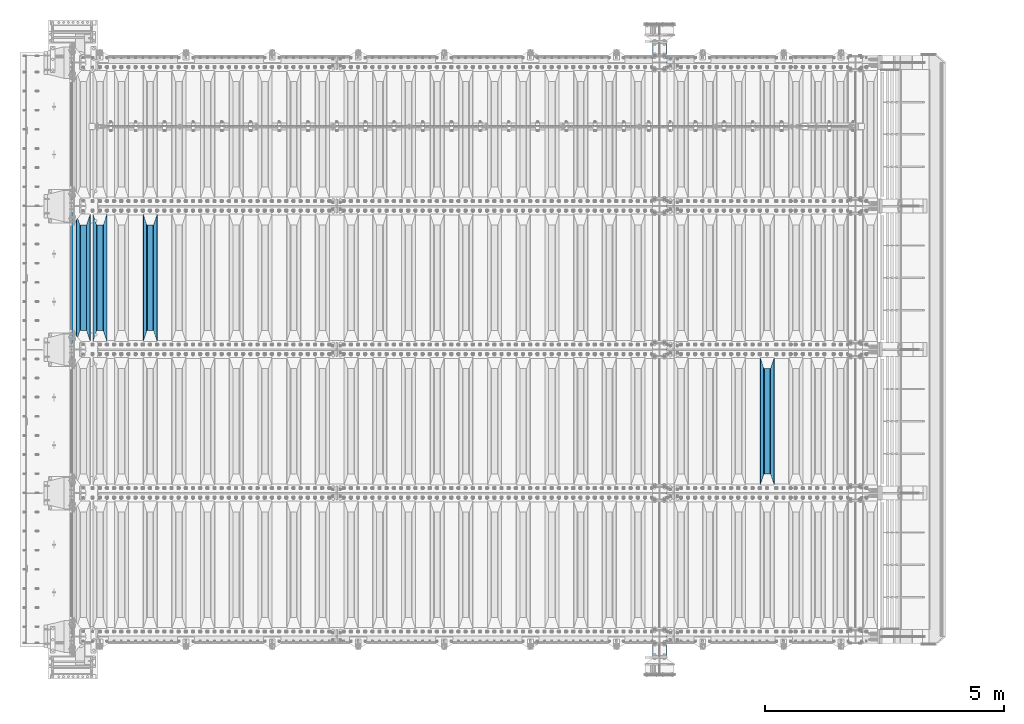
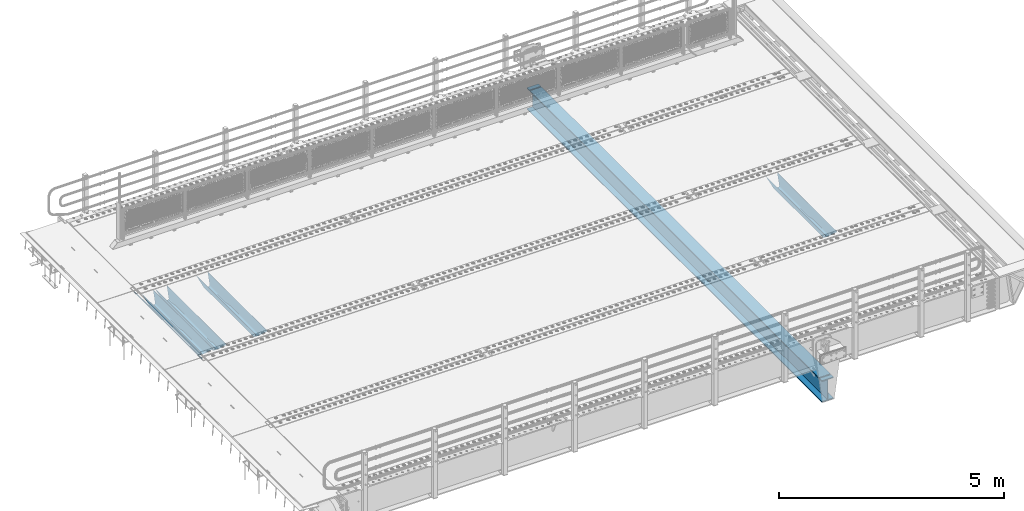
# One storey, part 113 of 257: 6 beams.
"""IFC2X3 building model written with IfcOpenShell, lengths in millimetres."""

from ifc_helpers import new_model, si_unit, frame, origin_with_axes, place, context, subcontext, project, spatial, faceted_brep, material, type_object, element, save


model = new_model("IFC2X3")

# Units and contexts
model_context = context("Model", 3, precision=1e-05, world=origin_with_axes())
body_context = subcontext(model_context, "Body", "Model", "MODEL_VIEW")
ifc_project = project(units=[si_unit("LENGTHUNIT", "METRE", prefix="MILLI"), si_unit("AREAUNIT", "SQUARE_METRE"), si_unit("VOLUMEUNIT", "CUBIC_METRE"), si_unit("MASSUNIT", "GRAM", prefix="KILO"), si_unit("TIMEUNIT", "SECOND"), si_unit("PLANEANGLEUNIT", "RADIAN"), si_unit("SOLIDANGLEUNIT", "STERADIAN"), si_unit("THERMODYNAMICTEMPERATUREUNIT", "DEGREE_CELSIUS"), si_unit("LUMINOUSINTENSITYUNIT", "LUMEN")], contexts=[model_context])

# Site, building, storey
site_placement = place(None, origin_with_axes())
site = spatial("IfcSite", under=ifc_project, at=site_placement, CompositionType="ELEMENT")
building_placement = place(site_placement, origin_with_axes())
building = spatial("IfcBuilding", under=site, at=building_placement, Name="Standard", CompositionType="ELEMENT")
storey_placement = place(building_placement, origin_with_axes())
storey = spatial("IfcBuildingStorey", under=building, at=storey_placement, Name="Undefined", CompositionType="ELEMENT", Elevation=0.0)

# Beams
ifc_material = material(Name="STEEL/S355N")
beam_type_1 = type_object("IfcBeamType", Name="D20", PredefinedType="NOTDEFINED")
beam_1_placement = place(storey_placement, frame((42415.0, 6004.99999999998, -25.999999994595), z_axis=(0.0, 0.0, 1.0), x_axis=(0.0, 1.0, 0.0)))
element("IfcBeam", 1, at=beam_1_placement, inside=storey, type_object=beam_type_1, material=ifc_material, ObjectType="D20", context=body_context, shape_type="Brep", body=[
    faceted_brep([(0.0, -10.0, 0.0), (0.0, -7.07106781186303, -7.07106781186548), (2990.0, -7.07106781186303, -7.07106781186548), (2990.0, -10.0, 0.0), (0.0, 0.0, -10.0), (2990.0, 0.0, -10.0), (0.0, 7.07106781186303, -7.07106781186547), (2990.0, 7.07106781186303, -7.07106781186547), (0.0, 10.0, 0.0), (2990.0, 10.0, 0.0), (0.0, 7.07106781186303, 7.07106781186548), (2990.0, 7.07106781186303, 7.07106781186548), (0.0, 0.0, 10.0), (2990.0, 0.0, 10.0), (0.0, -7.07106781186303, 7.07106781186548), (2990.0, -7.07106781186303, 7.07106781186548)], [[[0, 1, 2, 3]], [[1, 4, 5, 2]], [[4, 6, 7, 5]], [[6, 8, 9, 7]], [[8, 10, 11, 9]], [[10, 12, 13, 11]], [[12, 14, 15, 13]], [[14, 0, 3, 15]], [[5, 7, 9, 11, 13, 15, 3, 2]], [[14, 12, 10, 8, 6, 4, 1, 0]]]),
])
beam_type_2 = type_object("IfcBeamType", PredefinedType="NOTDEFINED")
beam_2_placement = place(storey_placement, frame((56950.0, 3175.0, -115.0), z_axis=(0.0, 0.0, 1.0), x_axis=(0.0, 1.0, 0.0)))
element("IfcBeam", 2, at=beam_2_placement, inside=storey, type_object=beam_type_2, material=ifc_material, context=body_context, shape_type="Brep", body=[
    faceted_brep([(0.0, 150.0, 115.0), (0.0, 143.690000000002, 115.0), (2650.00000000297, 143.690000000002, 115.0), (2650.00000000297, 150.0, 115.0), (2650.00000000297, 142.059565218406, 110.0000000031), (2650.00000000297, 148.369565218403, 110.0000000031), (2441.90079219208, -80.1103600731149, -98.0992078077845), (2437.7588105432, -77.5672621345584, -102.241189456673), (2434.06523489746, -74.4080125315522, -105.934765102404), (2430.91086095089, -70.7102721255724, -109.089139048974), (2428.37322971128, -66.5649389910031, -111.626770288588), (2426.51472138055, -62.0739139532889, -113.485278619323), (2425.38102192091, -57.3475956567636, -114.618978078955), (2424.99999999987, -52.5021667386536, -115.0), (2424.99999999987, 52.5021667386536, -115.0), (2425.38102192091, 57.3475956567636, -114.618978078955), (2426.51472138055, 62.0739139532889, -113.485278619323), (2428.37322971128, 66.5649389910031, -111.626770288588), (2430.91086095089, 70.7102721255724, -109.089139048974), (2434.06523489746, 74.4080125315522, -105.934765102404), (2437.7588105432, 77.5672621345584, -102.241189456673), (2441.90079219208, 80.1103600731149, -98.0992078077846), (2446.38936140511, 81.9747917625791, -93.6106385947584), (2448.24948500409, 76.2713538057287, -91.7505149957729), (2444.62967112262, 74.76777986261, -95.3703288772456), (2441.28936334126, 72.7168944282894, -98.710636658607), (2438.31067330438, 70.1691124903809, -101.689326695487), (2435.76682334747, 67.1870637758839, -104.233176652398), (2433.72034654133, 63.8440531834931, -106.279653458539), (2432.22154950041, 60.2222587982324, -107.778450499454), (2431.30727574265, 56.4107117849126, -108.692724257221), (2430.99999999987, 52.5031078186876, -109.0), (2430.99999999987, -52.5031078186876, -109.0), (2431.30727574265, -56.4107117849126, -108.692724257221), (2432.22154950041, -60.2222587982324, -107.778450499454), (2433.72034654133, -63.8440531834931, -106.279653458539), (2435.76682334747, -67.1870637758839, -104.233176652398), (2438.31067330438, -70.1691124903809, -101.689326695487), (2441.28936334126, -72.7168944282894, -98.7106366586071), (2444.62967112262, -74.76777986261, -95.3703288772457), (2448.24948500409, -76.2713538057287, -91.7505149957729), (2650.00000000297, -142.059565218406, 110.0000000031), (2650.00000000297, -148.369565218403, 110.0000000031), (2446.38936140511, -81.9747917625791, -93.6106385947584), (2650.00000000297, -143.690000000002, 115.0), (2650.00000000297, -150.0, 115.0), (0.0, -143.690000000002, 115.0), (0.0, -150.0, 115.0), (0.0, -148.369565218258, 110.000000002662), (203.61063859742, -81.9747917625791, -93.6106385947584), (208.099207810447, -80.1103600731149, -98.0992078077845), (212.241189459335, -77.5672621345584, -102.241189456673), (215.934765105066, -74.4080125315522, -105.934765102404), (219.089139051636, -70.7102721255724, -109.089139048974), (221.626770291251, -66.5649389910031, -111.626770288588), (223.485278621985, -62.0739139532889, -113.485278619323), (224.618978081617, -57.3475956567636, -114.618978078955), (225.000000002662, -52.5021667386536, -115.0), (225.000000002662, 52.5021667386536, -115.0), (224.618978081617, 57.3475956567636, -114.618978078955), (223.485278621985, 62.0739139532889, -113.485278619323), (221.626770291251, 66.5649389910031, -111.626770288588), (219.089139051636, 70.7102721255724, -109.089139048974), (215.934765105066, 74.4080125315522, -105.934765102404), (212.241189459335, 77.5672621345584, -102.241189456673), (208.099207810447, 80.1103600731149, -98.0992078077846), (203.61063859742, 81.9747917625791, -93.6106385947584), (0.0, 148.369565218258, 110.000000002662), (0.0, 142.05956521826, 110.000000002662), (201.750514998435, 76.2713538057287, -91.7505149957729), (205.370328879908, 74.76777986261, -95.3703288772456), (208.710636661269, 72.7168944282894, -98.710636658607), (211.689326698149, 70.1691124903809, -101.689326695487), (214.233176655061, 67.1870637758839, -104.233176652398), (216.279653461201, 63.8440531834931, -106.279653458539), (217.778450502116, 60.2222587982324, -107.778450499454), (218.692724259884, 56.4107117849126, -108.692724257221), (219.000000002662, 52.5031078186876, -109.0), (219.000000002662, -52.5031078186876, -109.0), (218.692724259884, -56.4107117849126, -108.692724257221), (217.778450502116, -60.2222587982324, -107.778450499454), (216.279653461201, -63.8440531834931, -106.279653458539), (214.233176655061, -67.1870637758839, -104.233176652398), (211.689326698149, -70.1691124903809, -101.689326695487), (208.710636661269, -72.7168944282894, -98.7106366586071), (205.370328879908, -74.76777986261, -95.3703288772457), (201.750514998435, -76.2713538057287, -91.7505149957729), (0.0, -142.05956521826, 110.000000002662)], [[[0, 1, 2, 3]], [[3, 2, 4, 5]], [[6, 7, 8, 9, 10, 11, 12, 13, 14, 15, 16, 17, 18, 19, 20, 21, 22, 5, 4, 23, 24, 25, 26, 27, 28, 29, 30, 31, 32, 33, 34, 35, 36, 37, 38, 39, 40, 41, 42, 43]], [[44, 45, 42, 41]], [[46, 47, 45, 44]], [[43, 42, 45, 47, 48, 49]], [[6, 43, 49, 50]], [[7, 6, 50, 51]], [[8, 7, 51, 52]], [[9, 8, 52, 53]], [[10, 9, 53, 54]], [[11, 10, 54, 55]], [[12, 11, 55, 56]], [[13, 12, 56, 57]], [[14, 13, 57, 58]], [[15, 14, 58, 59]], [[16, 15, 59, 60]], [[17, 16, 60, 61]], [[18, 17, 61, 62]], [[19, 18, 62, 63]], [[20, 19, 63, 64]], [[21, 20, 64, 65]], [[22, 21, 65, 66]], [[0, 3, 5, 22, 66, 67]], [[1, 0, 67, 68]], [[23, 4, 2, 1, 68, 69]], [[24, 23, 69, 70]], [[25, 24, 70, 71]], [[26, 25, 71, 72]], [[27, 26, 72, 73]], [[28, 27, 73, 74]], [[29, 28, 74, 75]], [[30, 29, 75, 76]], [[31, 30, 76, 77]], [[32, 31, 77, 78]], [[33, 32, 78, 79]], [[34, 33, 79, 80]], [[35, 34, 80, 81]], [[36, 35, 81, 82]], [[37, 36, 82, 83]], [[38, 37, 83, 84]], [[39, 38, 84, 85]], [[40, 39, 85, 86]], [[46, 44, 41, 40, 86, 87]], [[47, 46, 87, 48]], [[86, 85, 84, 83, 82, 81, 80, 79, 78, 77, 76, 75, 74, 73, 72, 71, 70, 69, 68, 67, 66, 65, 64, 63, 62, 61, 60, 59, 58, 57, 56, 55, 54, 53, 52, 51, 50, 49, 48, 87]]]),
])
beam_3_placement = place(storey_placement, frame((44050.0, 6175.0, -115.0), z_axis=(0.0, 0.0, 1.0), x_axis=(0.0, 1.0, 0.0)))
element("IfcBeam", 3, at=beam_3_placement, inside=storey, type_object=beam_type_2, material=ifc_material, context=body_context, shape_type="Brep", body=[
    faceted_brep([(0.0, 150.0, 115.0), (0.0, 143.690000000002, 115.0), (2650.00000000297, 143.690000000002, 115.0), (2650.00000000297, 150.0, 115.0), (2650.00000000297, 142.059565218406, 110.0000000031), (2650.00000000297, 148.369565218403, 110.0000000031), (2441.90079219208, -80.1103600731149, -98.0992078077845), (2437.7588105432, -77.5672621345584, -102.241189456673), (2434.06523489746, -74.4080125315522, -105.934765102404), (2430.91086095089, -70.7102721255724, -109.089139048974), (2428.37322971128, -66.5649389910031, -111.626770288588), (2426.51472138055, -62.0739139532889, -113.485278619323), (2425.38102192091, -57.3475956567636, -114.618978078955), (2424.99999999987, -52.5021667386536, -115.0), (2424.99999999987, 52.5021667386536, -115.0), (2425.38102192091, 57.3475956567636, -114.618978078955), (2426.51472138055, 62.0739139532889, -113.485278619323), (2428.37322971128, 66.5649389910031, -111.626770288588), (2430.91086095089, 70.7102721255724, -109.089139048974), (2434.06523489746, 74.4080125315522, -105.934765102404), (2437.7588105432, 77.5672621345584, -102.241189456673), (2441.90079219208, 80.1103600731149, -98.0992078077846), (2446.38936140511, 81.9747917625791, -93.6106385947584), (2448.24948500409, 76.2713538057287, -91.7505149957729), (2444.62967112262, 74.76777986261, -95.3703288772456), (2441.28936334126, 72.7168944282894, -98.710636658607), (2438.31067330438, 70.1691124903809, -101.689326695487), (2435.76682334747, 67.1870637758839, -104.233176652398), (2433.72034654133, 63.8440531834931, -106.279653458539), (2432.22154950041, 60.2222587982324, -107.778450499454), (2431.30727574265, 56.4107117849126, -108.692724257221), (2430.99999999987, 52.5031078186876, -109.0), (2430.99999999987, -52.5031078186876, -109.0), (2431.30727574265, -56.4107117849126, -108.692724257221), (2432.22154950041, -60.2222587982324, -107.778450499454), (2433.72034654133, -63.8440531834931, -106.279653458539), (2435.76682334747, -67.1870637758839, -104.233176652398), (2438.31067330438, -70.1691124903809, -101.689326695487), (2441.28936334126, -72.7168944282894, -98.7106366586071), (2444.62967112262, -74.76777986261, -95.3703288772457), (2448.24948500409, -76.2713538057287, -91.7505149957729), (2650.00000000297, -142.059565218406, 110.0000000031), (2650.00000000297, -148.369565218403, 110.0000000031), (2446.38936140511, -81.9747917625791, -93.6106385947584), (2650.00000000297, -143.690000000002, 115.0), (2650.00000000297, -150.0, 115.0), (0.0, -143.690000000002, 115.0), (0.0, -150.0, 115.0), (0.0, -148.369565218258, 110.000000002662), (203.61063859742, -81.9747917625791, -93.6106385947584), (208.099207810447, -80.1103600731149, -98.0992078077845), (212.241189459335, -77.5672621345584, -102.241189456673), (215.934765105066, -74.4080125315522, -105.934765102404), (219.089139051636, -70.7102721255724, -109.089139048974), (221.626770291251, -66.5649389910031, -111.626770288588), (223.485278621985, -62.0739139532889, -113.485278619323), (224.618978081617, -57.3475956567636, -114.618978078955), (225.000000002662, -52.5021667386536, -115.0), (225.000000002662, 52.5021667386536, -115.0), (224.618978081617, 57.3475956567636, -114.618978078955), (223.485278621985, 62.0739139532889, -113.485278619323), (221.626770291251, 66.5649389910031, -111.626770288588), (219.089139051636, 70.7102721255724, -109.089139048974), (215.934765105066, 74.4080125315522, -105.934765102404), (212.241189459335, 77.5672621345584, -102.241189456673), (208.099207810447, 80.1103600731149, -98.0992078077846), (203.61063859742, 81.9747917625791, -93.6106385947584), (0.0, 148.369565218258, 110.000000002662), (0.0, 142.05956521826, 110.000000002662), (201.750514998435, 76.2713538057287, -91.7505149957729), (205.370328879908, 74.76777986261, -95.3703288772456), (208.710636661269, 72.7168944282894, -98.710636658607), (211.689326698149, 70.1691124903809, -101.689326695487), (214.233176655061, 67.1870637758839, -104.233176652398), (216.279653461201, 63.8440531834931, -106.279653458539), (217.778450502116, 60.2222587982324, -107.778450499454), (218.692724259884, 56.4107117849126, -108.692724257221), (219.000000002662, 52.5031078186876, -109.0), (219.000000002662, -52.5031078186876, -109.0), (218.692724259884, -56.4107117849126, -108.692724257221), (217.778450502116, -60.2222587982324, -107.778450499454), (216.279653461201, -63.8440531834931, -106.279653458539), (214.233176655061, -67.1870637758839, -104.233176652398), (211.689326698149, -70.1691124903809, -101.689326695487), (208.710636661269, -72.7168944282894, -98.7106366586071), (205.370328879908, -74.76777986261, -95.3703288772457), (201.750514998435, -76.2713538057287, -91.7505149957729), (0.0, -142.05956521826, 110.000000002662)], [[[0, 1, 2, 3]], [[3, 2, 4, 5]], [[6, 7, 8, 9, 10, 11, 12, 13, 14, 15, 16, 17, 18, 19, 20, 21, 22, 5, 4, 23, 24, 25, 26, 27, 28, 29, 30, 31, 32, 33, 34, 35, 36, 37, 38, 39, 40, 41, 42, 43]], [[44, 45, 42, 41]], [[46, 47, 45, 44]], [[43, 42, 45, 47, 48, 49]], [[6, 43, 49, 50]], [[7, 6, 50, 51]], [[8, 7, 51, 52]], [[9, 8, 52, 53]], [[10, 9, 53, 54]], [[11, 10, 54, 55]], [[12, 11, 55, 56]], [[13, 12, 56, 57]], [[14, 13, 57, 58]], [[15, 14, 58, 59]], [[16, 15, 59, 60]], [[17, 16, 60, 61]], [[18, 17, 61, 62]], [[19, 18, 62, 63]], [[20, 19, 63, 64]], [[21, 20, 64, 65]], [[22, 21, 65, 66]], [[0, 3, 5, 22, 66, 67]], [[1, 0, 67, 68]], [[23, 4, 2, 1, 68, 69]], [[24, 23, 69, 70]], [[25, 24, 70, 71]], [[26, 25, 71, 72]], [[27, 26, 72, 73]], [[28, 27, 73, 74]], [[29, 28, 74, 75]], [[30, 29, 75, 76]], [[31, 30, 76, 77]], [[32, 31, 77, 78]], [[33, 32, 78, 79]], [[34, 33, 79, 80]], [[35, 34, 80, 81]], [[36, 35, 81, 82]], [[37, 36, 82, 83]], [[38, 37, 83, 84]], [[39, 38, 84, 85]], [[40, 39, 85, 86]], [[46, 44, 41, 40, 86, 87]], [[47, 46, 87, 48]], [[86, 85, 84, 83, 82, 81, 80, 79, 78, 77, 76, 75, 74, 73, 72, 71, 70, 69, 68, 67, 66, 65, 64, 63, 62, 61, 60, 59, 58, 57, 56, 55, 54, 53, 52, 51, 50, 49, 48, 87]]]),
])
beam_4_placement = place(storey_placement, frame((43000.0, 6175.0, -115.0), z_axis=(0.0, 0.0, 1.0), x_axis=(0.0, 1.0, 0.0)))
element("IfcBeam", 4, at=beam_4_placement, inside=storey, type_object=beam_type_2, material=ifc_material, context=body_context, shape_type="Brep", body=[
    faceted_brep([(0.0, 150.0, 115.0), (0.0, 143.690000000002, 115.0), (2650.00000000297, 143.690000000002, 115.0), (2650.00000000297, 150.0, 115.0), (2650.00000000297, 142.059565218406, 110.0000000031), (2650.00000000297, 148.369565218403, 110.0000000031), (2441.90079219208, -80.1103600731149, -98.0992078077845), (2437.7588105432, -77.5672621345584, -102.241189456673), (2434.06523489746, -74.4080125315522, -105.934765102404), (2430.91086095089, -70.7102721255724, -109.089139048974), (2428.37322971128, -66.5649389910031, -111.626770288588), (2426.51472138055, -62.0739139532889, -113.485278619323), (2425.38102192091, -57.3475956567636, -114.618978078955), (2424.99999999987, -52.5021667386536, -115.0), (2424.99999999987, 52.5021667386536, -115.0), (2425.38102192091, 57.3475956567636, -114.618978078955), (2426.51472138055, 62.0739139532889, -113.485278619323), (2428.37322971128, 66.5649389910031, -111.626770288588), (2430.91086095089, 70.7102721255724, -109.089139048974), (2434.06523489746, 74.4080125315522, -105.934765102404), (2437.7588105432, 77.5672621345584, -102.241189456673), (2441.90079219208, 80.1103600731149, -98.0992078077846), (2446.38936140511, 81.9747917625791, -93.6106385947584), (2448.24948500409, 76.2713538057287, -91.7505149957729), (2444.62967112262, 74.76777986261, -95.3703288772456), (2441.28936334126, 72.7168944282894, -98.710636658607), (2438.31067330438, 70.1691124903809, -101.689326695487), (2435.76682334747, 67.1870637758839, -104.233176652398), (2433.72034654133, 63.8440531834931, -106.279653458539), (2432.22154950041, 60.2222587982324, -107.778450499454), (2431.30727574265, 56.4107117849126, -108.692724257221), (2430.99999999987, 52.5031078186876, -109.0), (2430.99999999987, -52.5031078186876, -109.0), (2431.30727574265, -56.4107117849126, -108.692724257221), (2432.22154950041, -60.2222587982324, -107.778450499454), (2433.72034654133, -63.8440531834931, -106.279653458539), (2435.76682334747, -67.1870637758839, -104.233176652398), (2438.31067330438, -70.1691124903809, -101.689326695487), (2441.28936334126, -72.7168944282894, -98.7106366586071), (2444.62967112262, -74.76777986261, -95.3703288772457), (2448.24948500409, -76.2713538057287, -91.7505149957729), (2650.00000000297, -142.059565218406, 110.0000000031), (2650.00000000297, -148.369565218403, 110.0000000031), (2446.38936140511, -81.9747917625791, -93.6106385947584), (2650.00000000297, -143.690000000002, 115.0), (2650.00000000297, -150.0, 115.0), (0.0, -143.690000000002, 115.0), (0.0, -150.0, 115.0), (0.0, -148.369565218258, 110.000000002662), (203.61063859742, -81.9747917625791, -93.6106385947584), (208.099207810447, -80.1103600731149, -98.0992078077845), (212.241189459335, -77.5672621345584, -102.241189456673), (215.934765105066, -74.4080125315522, -105.934765102404), (219.089139051636, -70.7102721255724, -109.089139048974), (221.626770291251, -66.5649389910031, -111.626770288588), (223.485278621985, -62.0739139532889, -113.485278619323), (224.618978081617, -57.3475956567636, -114.618978078955), (225.000000002662, -52.5021667386536, -115.0), (225.000000002662, 52.5021667386536, -115.0), (224.618978081617, 57.3475956567636, -114.618978078955), (223.485278621985, 62.0739139532889, -113.485278619323), (221.626770291251, 66.5649389910031, -111.626770288588), (219.089139051636, 70.7102721255724, -109.089139048974), (215.934765105066, 74.4080125315522, -105.934765102404), (212.241189459335, 77.5672621345584, -102.241189456673), (208.099207810447, 80.1103600731149, -98.0992078077846), (203.61063859742, 81.9747917625791, -93.6106385947584), (0.0, 148.369565218258, 110.000000002662), (0.0, 142.05956521826, 110.000000002662), (201.750514998435, 76.2713538057287, -91.7505149957729), (205.370328879908, 74.76777986261, -95.3703288772456), (208.710636661269, 72.7168944282894, -98.710636658607), (211.689326698149, 70.1691124903809, -101.689326695487), (214.233176655061, 67.1870637758839, -104.233176652398), (216.279653461201, 63.8440531834931, -106.279653458539), (217.778450502116, 60.2222587982324, -107.778450499454), (218.692724259884, 56.4107117849126, -108.692724257221), (219.000000002662, 52.5031078186876, -109.0), (219.000000002662, -52.5031078186876, -109.0), (218.692724259884, -56.4107117849126, -108.692724257221), (217.778450502116, -60.2222587982324, -107.778450499454), (216.279653461201, -63.8440531834931, -106.279653458539), (214.233176655061, -67.1870637758839, -104.233176652398), (211.689326698149, -70.1691124903809, -101.689326695487), (208.710636661269, -72.7168944282894, -98.7106366586071), (205.370328879908, -74.76777986261, -95.3703288772457), (201.750514998435, -76.2713538057287, -91.7505149957729), (0.0, -142.05956521826, 110.000000002662)], [[[0, 1, 2, 3]], [[3, 2, 4, 5]], [[6, 7, 8, 9, 10, 11, 12, 13, 14, 15, 16, 17, 18, 19, 20, 21, 22, 5, 4, 23, 24, 25, 26, 27, 28, 29, 30, 31, 32, 33, 34, 35, 36, 37, 38, 39, 40, 41, 42, 43]], [[44, 45, 42, 41]], [[46, 47, 45, 44]], [[43, 42, 45, 47, 48, 49]], [[6, 43, 49, 50]], [[7, 6, 50, 51]], [[8, 7, 51, 52]], [[9, 8, 52, 53]], [[10, 9, 53, 54]], [[11, 10, 54, 55]], [[12, 11, 55, 56]], [[13, 12, 56, 57]], [[14, 13, 57, 58]], [[15, 14, 58, 59]], [[16, 15, 59, 60]], [[17, 16, 60, 61]], [[18, 17, 61, 62]], [[19, 18, 62, 63]], [[20, 19, 63, 64]], [[21, 20, 64, 65]], [[22, 21, 65, 66]], [[0, 3, 5, 22, 66, 67]], [[1, 0, 67, 68]], [[23, 4, 2, 1, 68, 69]], [[24, 23, 69, 70]], [[25, 24, 70, 71]], [[26, 25, 71, 72]], [[27, 26, 72, 73]], [[28, 27, 73, 74]], [[29, 28, 74, 75]], [[30, 29, 75, 76]], [[31, 30, 76, 77]], [[32, 31, 77, 78]], [[33, 32, 78, 79]], [[34, 33, 79, 80]], [[35, 34, 80, 81]], [[36, 35, 81, 82]], [[37, 36, 82, 83]], [[38, 37, 83, 84]], [[39, 38, 84, 85]], [[40, 39, 85, 86]], [[46, 44, 41, 40, 86, 87]], [[47, 46, 87, 48]], [[86, 85, 84, 83, 82, 81, 80, 79, 78, 77, 76, 75, 74, 73, 72, 71, 70, 69, 68, 67, 66, 65, 64, 63, 62, 61, 60, 59, 58, 57, 56, 55, 54, 53, 52, 51, 50, 49, 48, 87]]]),
])
beam_5_placement = place(storey_placement, frame((42650.0, 6175.0, -115.0), z_axis=(0.0, 0.0, 1.0), x_axis=(0.0, 1.0, 0.0)))
element("IfcBeam", 5, at=beam_5_placement, inside=storey, type_object=beam_type_2, material=ifc_material, context=body_context, shape_type="Brep", body=[
    faceted_brep([(0.0, 150.0, 115.0), (0.0, 143.690000000002, 115.0), (2650.00000000297, 143.690000000002, 115.0), (2650.00000000297, 150.0, 115.0), (2650.00000000297, 142.059565218406, 110.0000000031), (2650.00000000297, 148.369565218403, 110.0000000031), (2441.90079219208, -80.1103600731149, -98.0992078077845), (2437.7588105432, -77.5672621345584, -102.241189456673), (2434.06523489746, -74.4080125315522, -105.934765102404), (2430.91086095089, -70.7102721255724, -109.089139048974), (2428.37322971128, -66.5649389910031, -111.626770288588), (2426.51472138055, -62.0739139532889, -113.485278619323), (2425.38102192091, -57.3475956567636, -114.618978078955), (2424.99999999987, -52.5021667386536, -115.0), (2424.99999999987, 52.5021667386536, -115.0), (2425.38102192091, 57.3475956567636, -114.618978078955), (2426.51472138055, 62.0739139532889, -113.485278619323), (2428.37322971128, 66.5649389910031, -111.626770288588), (2430.91086095089, 70.7102721255724, -109.089139048974), (2434.06523489746, 74.4080125315522, -105.934765102404), (2437.7588105432, 77.5672621345584, -102.241189456673), (2441.90079219208, 80.1103600731149, -98.0992078077846), (2446.38936140511, 81.9747917625791, -93.6106385947584), (2448.24948500409, 76.2713538057287, -91.7505149957729), (2444.62967112262, 74.76777986261, -95.3703288772456), (2441.28936334126, 72.7168944282894, -98.710636658607), (2438.31067330438, 70.1691124903809, -101.689326695487), (2435.76682334747, 67.1870637758839, -104.233176652398), (2433.72034654133, 63.8440531834931, -106.279653458539), (2432.22154950041, 60.2222587982324, -107.778450499454), (2431.30727574265, 56.4107117849126, -108.692724257221), (2430.99999999987, 52.5031078186876, -109.0), (2430.99999999987, -52.5031078186876, -109.0), (2431.30727574265, -56.4107117849126, -108.692724257221), (2432.22154950041, -60.2222587982324, -107.778450499454), (2433.72034654133, -63.8440531834931, -106.279653458539), (2435.76682334747, -67.1870637758839, -104.233176652398), (2438.31067330438, -70.1691124903809, -101.689326695487), (2441.28936334126, -72.7168944282894, -98.7106366586071), (2444.62967112262, -74.76777986261, -95.3703288772457), (2448.24948500409, -76.2713538057287, -91.7505149957729), (2650.00000000297, -142.059565218406, 110.0000000031), (2650.00000000297, -148.369565218403, 110.0000000031), (2446.38936140511, -81.9747917625791, -93.6106385947584), (2650.00000000297, -143.690000000002, 115.0), (2650.00000000297, -150.0, 115.0), (0.0, -143.690000000002, 115.0), (0.0, -150.0, 115.0), (0.0, -148.369565218258, 110.000000002662), (203.61063859742, -81.9747917625791, -93.6106385947584), (208.099207810447, -80.1103600731149, -98.0992078077845), (212.241189459335, -77.5672621345584, -102.241189456673), (215.934765105066, -74.4080125315522, -105.934765102404), (219.089139051636, -70.7102721255724, -109.089139048974), (221.626770291251, -66.5649389910031, -111.626770288588), (223.485278621985, -62.0739139532889, -113.485278619323), (224.618978081617, -57.3475956567636, -114.618978078955), (225.000000002662, -52.5021667386536, -115.0), (225.000000002662, 52.5021667386536, -115.0), (224.618978081617, 57.3475956567636, -114.618978078955), (223.485278621985, 62.0739139532889, -113.485278619323), (221.626770291251, 66.5649389910031, -111.626770288588), (219.089139051636, 70.7102721255724, -109.089139048974), (215.934765105066, 74.4080125315522, -105.934765102404), (212.241189459335, 77.5672621345584, -102.241189456673), (208.099207810447, 80.1103600731149, -98.0992078077846), (203.61063859742, 81.9747917625791, -93.6106385947584), (0.0, 148.369565218258, 110.000000002662), (0.0, 142.05956521826, 110.000000002662), (201.750514998435, 76.2713538057287, -91.7505149957729), (205.370328879908, 74.76777986261, -95.3703288772456), (208.710636661269, 72.7168944282894, -98.710636658607), (211.689326698149, 70.1691124903809, -101.689326695487), (214.233176655061, 67.1870637758839, -104.233176652398), (216.279653461201, 63.8440531834931, -106.279653458539), (217.778450502116, 60.2222587982324, -107.778450499454), (218.692724259884, 56.4107117849126, -108.692724257221), (219.000000002662, 52.5031078186876, -109.0), (219.000000002662, -52.5031078186876, -109.0), (218.692724259884, -56.4107117849126, -108.692724257221), (217.778450502116, -60.2222587982324, -107.778450499454), (216.279653461201, -63.8440531834931, -106.279653458539), (214.233176655061, -67.1870637758839, -104.233176652398), (211.689326698149, -70.1691124903809, -101.689326695487), (208.710636661269, -72.7168944282894, -98.7106366586071), (205.370328879908, -74.76777986261, -95.3703288772457), (201.750514998435, -76.2713538057287, -91.7505149957729), (0.0, -142.05956521826, 110.000000002662)], [[[0, 1, 2, 3]], [[3, 2, 4, 5]], [[6, 7, 8, 9, 10, 11, 12, 13, 14, 15, 16, 17, 18, 19, 20, 21, 22, 5, 4, 23, 24, 25, 26, 27, 28, 29, 30, 31, 32, 33, 34, 35, 36, 37, 38, 39, 40, 41, 42, 43]], [[44, 45, 42, 41]], [[46, 47, 45, 44]], [[43, 42, 45, 47, 48, 49]], [[6, 43, 49, 50]], [[7, 6, 50, 51]], [[8, 7, 51, 52]], [[9, 8, 52, 53]], [[10, 9, 53, 54]], [[11, 10, 54, 55]], [[12, 11, 55, 56]], [[13, 12, 56, 57]], [[14, 13, 57, 58]], [[15, 14, 58, 59]], [[16, 15, 59, 60]], [[17, 16, 60, 61]], [[18, 17, 61, 62]], [[19, 18, 62, 63]], [[20, 19, 63, 64]], [[21, 20, 64, 65]], [[22, 21, 65, 66]], [[0, 3, 5, 22, 66, 67]], [[1, 0, 67, 68]], [[23, 4, 2, 1, 68, 69]], [[24, 23, 69, 70]], [[25, 24, 70, 71]], [[26, 25, 71, 72]], [[27, 26, 72, 73]], [[28, 27, 73, 74]], [[29, 28, 74, 75]], [[30, 29, 75, 76]], [[31, 30, 76, 77]], [[32, 31, 77, 78]], [[33, 32, 78, 79]], [[34, 33, 79, 80]], [[35, 34, 80, 81]], [[36, 35, 81, 82]], [[37, 36, 82, 83]], [[38, 37, 83, 84]], [[39, 38, 84, 85]], [[40, 39, 85, 86]], [[46, 44, 41, 40, 86, 87]], [[47, 46, 87, 48]], [[86, 85, 84, 83, 82, 81, 80, 79, 78, 77, 76, 75, 74, 73, 72, 71, 70, 69, 68, 67, 66, 65, 64, 63, 62, 61, 60, 59, 58, 57, 56, 55, 54, 53, 52, 51, 50, 49, 48, 87]]]),
])
beam_type_3 = type_object("IfcBeamType", Name="HEA600", PredefinedType="NOTDEFINED")
beam_6_placement = place(storey_placement, frame((54700.0, -564.999999995798, -1185.00001953686), z_axis=(0.0, 0.0, 1.0), x_axis=(0.0, 1.0, 0.0)))
element("IfcBeam", 6, at=beam_6_placement, inside=storey, type_object=beam_type_3, material=ifc_material, ObjectType="HEA600", context=body_context, shape_type="Brep", body=[
    faceted_brep([(12990.0, -150.0, 295.0), (12990.0, -150.0, 270.0), (12990.0, -6.5, 270.0), (12990.0, -6.5, 295.0), (13020.0, -6.5, 270.0), (13020.0, -6.5, 295.0), (13020.0, -150.0, 295.0), (13020.0, -150.0, 270.0), (13130.0, -150.0, 270.0), (13130.0, -150.0, 295.0), (13130.0, -6.5, 270.0), (13130.0, 150.0, 295.0), (13130.0, 150.0, 270.0), (13020.0, 150.0, 270.0), (13020.0, 150.0, 295.0), (12990.0, 150.0, 270.0), (12990.0, 6.5, 270.0), (140.000000114262, 6.5, 270.0), (140.000000394781, 150.0, 270.0), (0.0, -150.0, -295.0), (0.0, 150.0, -295.0), (13130.0, 150.0, -295.0), (13130.0, -150.0, -295.0), (13020.0, -150.0, -270.0), (12990.0, -150.0, -270.0), (139.999999808327, -150.0, -270.0), (109.999999808326, -150.0, -270.0), (0.0, -150.0, -270.0), (13130.0, -150.0, -270.0), (13020.0, -6.5, -270.0), (12990.0, -6.5, -270.0), (140.000000095165, -6.5, -270.0), (110.000000095326, -6.5, -270.0), (0.0, -6.5, -270.0), (13130.0, -6.5, -270.0), (0.0, -150.0, 270.0), (0.0, -6.5, 270.0), (110.000000095324, -6.5, 270.0), (109.999999808326, -150.0, 270.0), (139.999999808327, -150.0, 295.0), (140.000000095165, -6.5, 295.0), (140.000000095165, -6.5, 270.0), (139.999999808327, -150.0, 270.0), (110.000000095327, -6.49999994000245, 295.0), (109.999999808326, -150.0, 295.0), (0.0, -150.0, 295.0), (0.0, 6.5, 270.0), (0.0, 150.0, 270.0), (110.000000394783, 150.0, 270.0), (110.000000394783, 6.5, 270.0), (0.0, 150.0, 295.0), (0.0, 6.5, -270.0), (0.0, 150.0, -270.0), (110.000000394783, 150.0, 295.0), (110.000000394783, 6.5, 295.0), (140.000000114261, 6.5, 295.0), (140.000000394781, 150.0, 295.0), (12990.0, 150.0, 295.0), (12990.0, 6.5, 295.0), (13020.0, 6.5, 295.0), (13020.0, 6.5, 270.0), (13130.0, 6.5, 270.0), (13020.0, 6.5, -270.0), (12990.0, 6.5, -270.0), (140.000000114262, 6.5, -270.0), (110.000000394783, 6.5, -270.0), (13130.0, 6.5, -270.0), (13020.0, 150.0, -270.0), (12990.0, 150.0, -270.0), (140.000000394783, 150.0, -270.0), (110.000000394783, 150.0, -270.0), (13130.0, 150.0, -270.0)], [[[0, 1, 2, 3]], [[3, 2, 4, 5]], [[6, 5, 4, 7]], [[8, 9, 6, 7]], [[10, 8, 7, 4]], [[11, 12, 13, 14]], [[15, 16, 17, 18]], [[19, 20, 21, 22]], [[23, 24, 25, 26, 27, 19, 22, 28]], [[29, 30, 31, 32, 33, 27, 26, 25, 24, 23, 28, 34]], [[35, 36, 37, 38]], [[39, 40, 41, 42]], [[43, 37, 41, 40]], [[44, 38, 37, 43]], [[45, 35, 38, 44]], [[46, 47, 48, 49]], [[19, 27, 33, 36, 35, 45, 50, 47, 46, 51, 52, 20]], [[47, 50, 53, 48]], [[54, 49, 48, 53]], [[55, 17, 49, 54]], [[56, 18, 17, 55]], [[57, 15, 18, 56]], [[58, 16, 15, 57]], [[59, 60, 16, 58]], [[14, 13, 60, 59]], [[12, 61, 60, 13]], [[62, 63, 64, 65, 51, 46, 49, 17, 16, 60, 61, 66]], [[67, 68, 69, 70, 52, 51, 65, 64, 63, 62, 66, 71]], [[20, 52, 70, 69, 68, 67, 71, 21]], [[66, 61, 12, 11, 9, 8, 10, 34, 28, 22, 21, 71]], [[4, 2, 41, 37, 36, 33, 32, 31, 30, 29, 34, 10]], [[42, 41, 2, 1]], [[39, 42, 1, 0]], [[9, 11, 14, 59, 58, 57, 56, 55, 54, 53, 50, 45, 44, 43, 40, 39, 0, 3, 5, 6]]]),
])

save(model, "model.ifc")
